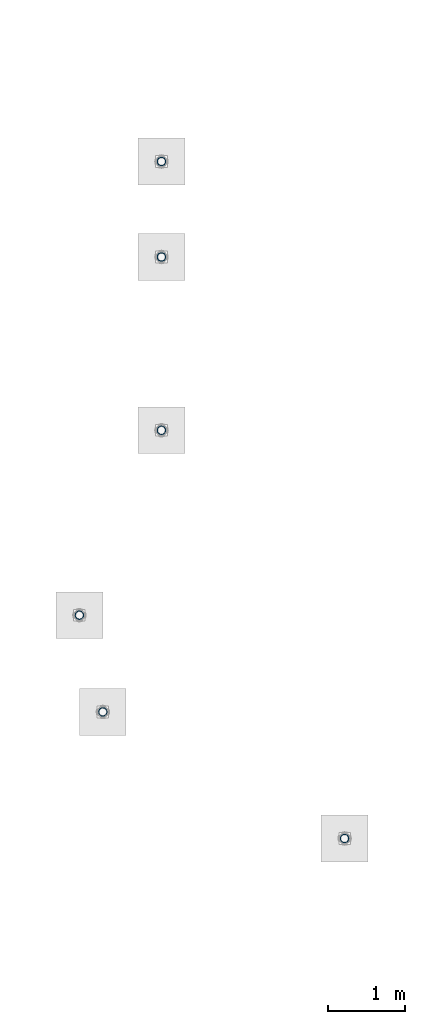
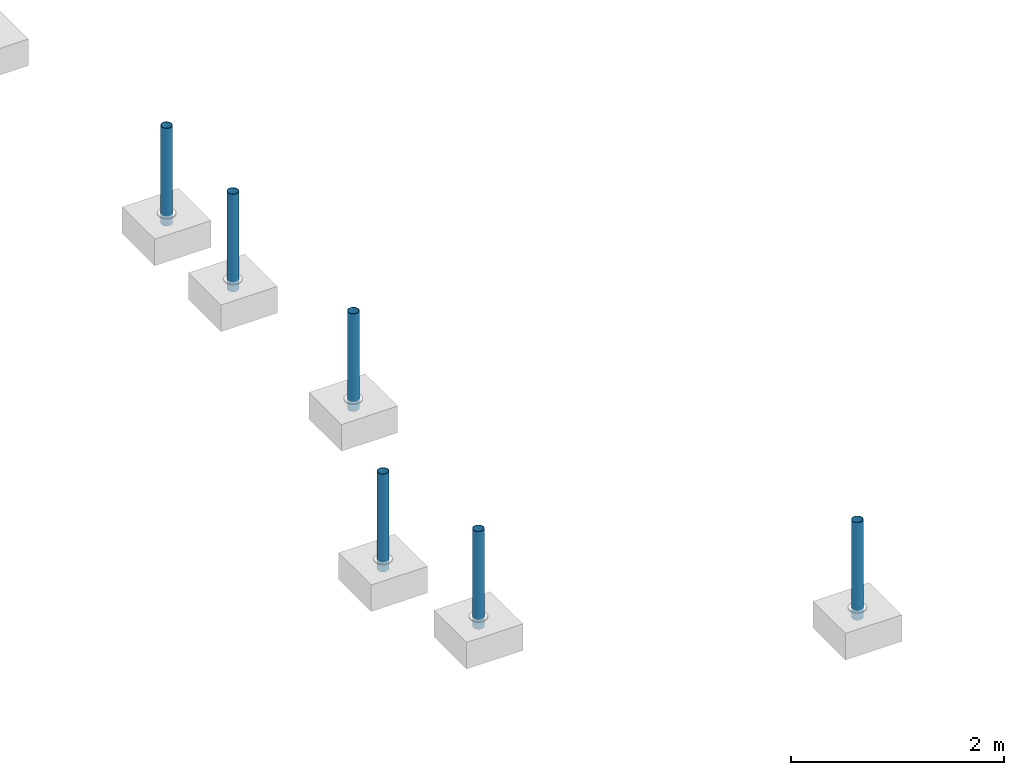
# One storey, part 1341 of 3843: 6 columns, 6 elements without a shape of their own.
"""IFC2X3 building model written with IfcOpenShell, lengths in millimetres."""

from ifc_helpers import new_model, si_unit, frame, origin_with_axes, place, context, subcontext, project, spatial, faceted_brep, material, type_object, element, aggregate, save


model = new_model("IFC2X3")

# Units and contexts
model_context = context("Model", 3, precision=1e-05, world=origin_with_axes())
body_context = subcontext(model_context, "Body", "Model", "MODEL_VIEW")
ifc_project = project(units=[si_unit("LENGTHUNIT", "METRE", prefix="MILLI"), si_unit("AREAUNIT", "SQUARE_METRE"), si_unit("VOLUMEUNIT", "CUBIC_METRE"), si_unit("MASSUNIT", "GRAM", prefix="KILO"), si_unit("TIMEUNIT", "SECOND"), si_unit("PLANEANGLEUNIT", "RADIAN"), si_unit("SOLIDANGLEUNIT", "STERADIAN"), si_unit("THERMODYNAMICTEMPERATUREUNIT", "DEGREE_CELSIUS"), si_unit("LUMINOUSINTENSITYUNIT", "LUMEN")], contexts=[model_context])

# Site, building, storey
site_placement = place(None, origin_with_axes())
site = spatial("IfcSite", under=ifc_project, at=site_placement, CompositionType="ELEMENT")
building_placement = place(site_placement, origin_with_axes())
building = spatial("IfcBuilding", under=site, at=building_placement, Name="Undefined", CompositionType="ELEMENT")
storey_placement = place(building_placement, origin_with_axes())
storey = spatial("IfcBuildingStorey", under=building, at=storey_placement, Name="Undefined", CompositionType="ELEMENT", Elevation=0.0)

# Assembly, column
assembly_1_placement = place(storey_placement, origin_with_axes())
assembly_1 = element("IfcElementAssembly", 1, at=assembly_1_placement, inside=storey, Name="PIPE_BOLLARD", AssemblyPlace="NOTDEFINED", PredefinedType="RIGID_FRAME")
ifc_material = material()
column_type = type_object("IfcColumnType", Name="PIPE4SCH40", PredefinedType="NOTDEFINED")
column_1_placement = place(assembly_1_placement, frame((-13009.9315797985, 80350.2009584904, 30378.4), z_axis=(-1.0, 0.0, 0.0), x_axis=(0.0, 0.0, 1.0)))
column_1 = element("IfcColumn", 2, at=column_1_placement, type_object=column_type, material=ifc_material, Name="PIPE_BOLLARD", ObjectType="PIPE4SCH40", context=body_context, shape_type="Brep", body=[
    faceted_brep([(0.0, -51.1301999999996, 0.0), (0.0, -48.6277098894743, 15.8001007257844), (1117.6, -48.6277098894743, 15.8001007257844), (1117.6, -51.1301999999996, 0.0), (0.0, -41.3652007257897, 30.0535775067692), (1117.6, -41.3652007257897, 30.0535775067692), (0.0, -30.0535775067647, 41.3652007257915), (1117.6, -30.0535775067647, 41.3652007257915), (0.0, -15.8001007257899, 48.6277098894789), (1117.6, -15.8001007257899, 48.6277098894789), (0.0, 0.0, 51.1301999999996), (1117.6, 0.0, 51.1301999999996), (0.0, 15.8001007257899, 48.6277098894789), (1117.6, 15.8001007257899, 48.6277098894789), (0.0, 30.0535775067647, 41.3652007257915), (1117.6, 30.0535775067647, 41.3652007257915), (0.0, 41.3652007257897, 30.0535775067692), (1117.6, 41.3652007257897, 30.0535775067692), (0.0, 48.6277098894743, 15.8001007257844), (1117.6, 48.6277098894743, 15.8001007257844), (0.0, 51.1301999999996, 0.0), (1117.6, 51.1301999999996, 0.0), (0.0, 48.6277098894743, -15.8001007257844), (1117.6, 48.6277098894743, -15.8001007257844), (0.0, 41.3652007257897, -30.0535775067692), (1117.6, 41.3652007257897, -30.0535775067692), (0.0, 30.0535775067647, -41.3652007257915), (1117.6, 30.0535775067647, -41.3652007257915), (0.0, 15.8001007257899, -48.6277098894789), (1117.6, 15.8001007257899, -48.6277098894789), (0.0, 0.0, -51.1301999999996), (1117.6, 0.0, -51.1301999999996), (0.0, -15.8001007257899, -48.6277098894789), (1117.6, -15.8001007257899, -48.6277098894789), (0.0, -30.0535775067647, -41.3652007257915), (1117.6, -30.0535775067647, -41.3652007257915), (0.0, -41.3652007257897, -30.0535775067692), (1117.6, -41.3652007257897, -30.0535775067692), (0.0, -48.6277098894743, -15.8001007257844), (1117.6, -48.6277098894743, -15.8001007257844), (0.0, -57.1499999999996, 0.0), (0.0, -54.3528799062678, -17.6603212285263), (1117.6, -54.3528799062678, -17.6603212285263), (1117.6, -57.1499999999996, 0.0), (0.0, -46.2353212285279, -33.5919271685125), (1117.6, -46.2353212285279, -33.5919271685125), (0.0, -33.5919271685152, -46.2353212285234), (1117.6, -33.5919271685152, -46.2353212285234), (0.0, -17.6603212285281, -54.3528799062624), (1117.6, -17.6603212285281, -54.3528799062624), (0.0, 0.0, -57.1499999999942), (1117.6, 0.0, -57.1499999999942), (0.0, 17.6603212285281, -54.3528799062624), (1117.6, 17.6603212285281, -54.3528799062624), (0.0, 33.5919271685152, -46.2353212285234), (1117.6, 33.5919271685152, -46.2353212285234), (0.0, 46.2353212285279, -33.5919271685125), (1117.6, 46.2353212285279, -33.5919271685125), (0.0, 54.3528799062678, -17.6603212285263), (1117.6, 54.3528799062678, -17.6603212285263), (0.0, 57.1499999999996, 0.0), (1117.6, 57.1499999999996, 0.0), (0.0, 54.3528799062678, 17.6603212285263), (1117.6, 54.3528799062678, 17.6603212285263), (0.0, 46.2353212285279, 33.5919271685125), (1117.6, 46.2353212285279, 33.5919271685125), (0.0, 33.5919271685152, 46.2353212285234), (1117.6, 33.5919271685152, 46.2353212285234), (0.0, 17.6603212285281, 54.3528799062624), (1117.6, 17.6603212285281, 54.3528799062624), (0.0, 0.0, 57.1499999999942), (1117.6, 0.0, 57.1499999999942), (0.0, -17.6603212285281, 54.3528799062624), (1117.6, -17.6603212285281, 54.3528799062624), (0.0, -33.5919271685152, 46.2353212285234), (1117.6, -33.5919271685152, 46.2353212285234), (0.0, -46.2353212285279, 33.5919271685125), (1117.6, -46.2353212285279, 33.5919271685125), (0.0, -54.3528799062678, 17.6603212285263), (1117.6, -54.3528799062678, 17.6603212285263)], [[[0, 1, 2, 3]], [[1, 4, 5, 2]], [[4, 6, 7, 5]], [[6, 8, 9, 7]], [[8, 10, 11, 9]], [[10, 12, 13, 11]], [[12, 14, 15, 13]], [[14, 16, 17, 15]], [[16, 18, 19, 17]], [[18, 20, 21, 19]], [[20, 22, 23, 21]], [[22, 24, 25, 23]], [[24, 26, 27, 25]], [[26, 28, 29, 27]], [[28, 30, 31, 29]], [[30, 32, 33, 31]], [[32, 34, 35, 33]], [[34, 36, 37, 35]], [[36, 38, 39, 37]], [[38, 0, 3, 39]], [[40, 41, 42, 43]], [[41, 44, 45, 42]], [[44, 46, 47, 45]], [[46, 48, 49, 47]], [[48, 50, 51, 49]], [[50, 52, 53, 51]], [[52, 54, 55, 53]], [[54, 56, 57, 55]], [[56, 58, 59, 57]], [[58, 60, 61, 59]], [[60, 62, 63, 61]], [[62, 64, 65, 63]], [[64, 66, 67, 65]], [[66, 68, 69, 67]], [[68, 70, 71, 69]], [[70, 72, 73, 71]], [[72, 74, 75, 73]], [[74, 76, 77, 75]], [[76, 78, 79, 77]], [[78, 40, 43, 79]], [[45, 47, 49, 51, 53, 55, 57, 59, 61, 63, 65, 67, 69, 71, 73, 75, 77, 79, 43, 42], [5, 7, 9, 11, 13, 15, 17, 19, 21, 23, 25, 27, 29, 31, 33, 35, 37, 39, 3, 2]], [[78, 76, 74, 72, 70, 68, 66, 64, 62, 60, 58, 56, 54, 52, 50, 48, 46, 44, 41, 40], [38, 36, 34, 32, 30, 28, 26, 24, 22, 20, 18, 16, 14, 12, 10, 8, 6, 4, 1, 0]]]),
])
aggregate(assembly_1, [column_1])

assembly_2_placement = place(storey_placement, origin_with_axes())
assembly_2 = element("IfcElementAssembly", 3, at=assembly_2_placement, inside=storey, Name="PIPE_BOLLARD", AssemblyPlace="NOTDEFINED", PredefinedType="RIGID_FRAME")
column_2_placement = place(assembly_2_placement, frame((-16161.9587099254, 81999.8381807804, 30378.4), z_axis=(-1.0, 0.0, 0.0), x_axis=(0.0, 0.0, 1.0)))
column_2 = element("IfcColumn", 4, at=column_2_placement, type_object=column_type, material=ifc_material, Name="PIPE_BOLLARD", ObjectType="PIPE4SCH40", context=body_context, shape_type="Brep", body=[
    faceted_brep([(0.0, -51.1301999999996, 0.0), (0.0, -48.6277098894743, 15.8001007257844), (1117.6, -48.6277098894743, 15.8001007257844), (1117.6, -51.1301999999996, 0.0), (0.0, -41.3652007257897, 30.0535775067692), (1117.6, -41.3652007257897, 30.0535775067692), (0.0, -30.0535775067647, 41.3652007257915), (1117.6, -30.0535775067647, 41.3652007257915), (0.0, -15.8001007257899, 48.6277098894789), (1117.6, -15.8001007257899, 48.6277098894789), (0.0, 0.0, 51.1301999999996), (1117.6, 0.0, 51.1301999999996), (0.0, 15.8001007257899, 48.6277098894789), (1117.6, 15.8001007257899, 48.6277098894789), (0.0, 30.0535775067647, 41.3652007257915), (1117.6, 30.0535775067647, 41.3652007257915), (0.0, 41.3652007257897, 30.0535775067692), (1117.6, 41.3652007257897, 30.0535775067692), (0.0, 48.6277098894743, 15.8001007257844), (1117.6, 48.6277098894743, 15.8001007257844), (0.0, 51.1301999999996, 0.0), (1117.6, 51.1301999999996, 0.0), (0.0, 48.6277098894743, -15.8001007257844), (1117.6, 48.6277098894743, -15.8001007257844), (0.0, 41.3652007257897, -30.0535775067692), (1117.6, 41.3652007257897, -30.0535775067692), (0.0, 30.0535775067647, -41.3652007257915), (1117.6, 30.0535775067647, -41.3652007257915), (0.0, 15.8001007257899, -48.6277098894789), (1117.6, 15.8001007257899, -48.6277098894789), (0.0, 0.0, -51.1301999999996), (1117.6, 0.0, -51.1301999999996), (0.0, -15.8001007257899, -48.6277098894789), (1117.6, -15.8001007257899, -48.6277098894789), (0.0, -30.0535775067647, -41.3652007257915), (1117.6, -30.0535775067647, -41.3652007257915), (0.0, -41.3652007257897, -30.0535775067692), (1117.6, -41.3652007257897, -30.0535775067692), (0.0, -48.6277098894743, -15.8001007257844), (1117.6, -48.6277098894743, -15.8001007257844), (0.0, -57.1499999999996, 0.0), (0.0, -54.3528799062678, -17.6603212285263), (1117.6, -54.3528799062678, -17.6603212285263), (1117.6, -57.1499999999996, 0.0), (0.0, -46.2353212285279, -33.5919271685125), (1117.6, -46.2353212285279, -33.5919271685125), (0.0, -33.5919271685152, -46.2353212285234), (1117.6, -33.5919271685152, -46.2353212285234), (0.0, -17.6603212285281, -54.3528799062624), (1117.6, -17.6603212285281, -54.3528799062624), (0.0, 0.0, -57.1499999999942), (1117.6, 0.0, -57.1499999999942), (0.0, 17.6603212285281, -54.3528799062624), (1117.6, 17.6603212285281, -54.3528799062624), (0.0, 33.5919271685152, -46.2353212285234), (1117.6, 33.5919271685152, -46.2353212285234), (0.0, 46.2353212285279, -33.5919271685125), (1117.6, 46.2353212285279, -33.5919271685125), (0.0, 54.3528799062678, -17.6603212285263), (1117.6, 54.3528799062678, -17.6603212285263), (0.0, 57.1499999999996, 0.0), (1117.6, 57.1499999999996, 0.0), (0.0, 54.3528799062678, 17.6603212285263), (1117.6, 54.3528799062678, 17.6603212285263), (0.0, 46.2353212285279, 33.5919271685125), (1117.6, 46.2353212285279, 33.5919271685125), (0.0, 33.5919271685152, 46.2353212285234), (1117.6, 33.5919271685152, 46.2353212285234), (0.0, 17.6603212285281, 54.3528799062624), (1117.6, 17.6603212285281, 54.3528799062624), (0.0, 0.0, 57.1499999999942), (1117.6, 0.0, 57.1499999999942), (0.0, -17.6603212285281, 54.3528799062624), (1117.6, -17.6603212285281, 54.3528799062624), (0.0, -33.5919271685152, 46.2353212285234), (1117.6, -33.5919271685152, 46.2353212285234), (0.0, -46.2353212285279, 33.5919271685125), (1117.6, -46.2353212285279, 33.5919271685125), (0.0, -54.3528799062678, 17.6603212285263), (1117.6, -54.3528799062678, 17.6603212285263)], [[[0, 1, 2, 3]], [[1, 4, 5, 2]], [[4, 6, 7, 5]], [[6, 8, 9, 7]], [[8, 10, 11, 9]], [[10, 12, 13, 11]], [[12, 14, 15, 13]], [[14, 16, 17, 15]], [[16, 18, 19, 17]], [[18, 20, 21, 19]], [[20, 22, 23, 21]], [[22, 24, 25, 23]], [[24, 26, 27, 25]], [[26, 28, 29, 27]], [[28, 30, 31, 29]], [[30, 32, 33, 31]], [[32, 34, 35, 33]], [[34, 36, 37, 35]], [[36, 38, 39, 37]], [[38, 0, 3, 39]], [[40, 41, 42, 43]], [[41, 44, 45, 42]], [[44, 46, 47, 45]], [[46, 48, 49, 47]], [[48, 50, 51, 49]], [[50, 52, 53, 51]], [[52, 54, 55, 53]], [[54, 56, 57, 55]], [[56, 58, 59, 57]], [[58, 60, 61, 59]], [[60, 62, 63, 61]], [[62, 64, 65, 63]], [[64, 66, 67, 65]], [[66, 68, 69, 67]], [[68, 70, 71, 69]], [[70, 72, 73, 71]], [[72, 74, 75, 73]], [[74, 76, 77, 75]], [[76, 78, 79, 77]], [[78, 40, 43, 79]], [[45, 47, 49, 51, 53, 55, 57, 59, 61, 63, 65, 67, 69, 71, 73, 75, 77, 79, 43, 42], [5, 7, 9, 11, 13, 15, 17, 19, 21, 23, 25, 27, 29, 31, 33, 35, 37, 39, 3, 2]], [[78, 76, 74, 72, 70, 68, 66, 64, 62, 60, 58, 56, 54, 52, 50, 48, 46, 44, 41, 40], [38, 36, 34, 32, 30, 28, 26, 24, 22, 20, 18, 16, 14, 12, 10, 8, 6, 4, 1, 0]]]),
])
aggregate(assembly_2, [column_2])

assembly_3_placement = place(storey_placement, origin_with_axes())
assembly_3 = element("IfcElementAssembly", 5, at=assembly_3_placement, inside=storey, Name="PIPE_BOLLARD", AssemblyPlace="NOTDEFINED", PredefinedType="RIGID_FRAME")
column_3_placement = place(assembly_3_placement, frame((-16467.6075136364, 83260.6490328312, 30378.4), z_axis=(-1.0, 0.0, 0.0), x_axis=(0.0, 0.0, 1.0)))
column_3 = element("IfcColumn", 6, at=column_3_placement, type_object=column_type, material=ifc_material, Name="PIPE_BOLLARD", ObjectType="PIPE4SCH40", context=body_context, shape_type="Brep", body=[
    faceted_brep([(0.0, -51.1301999999996, 0.0), (0.0, -48.6277098894743, 15.8001007257844), (1117.6, -48.6277098894743, 15.8001007257844), (1117.6, -51.1301999999996, 0.0), (0.0, -41.3652007257897, 30.0535775067692), (1117.6, -41.3652007257897, 30.0535775067692), (0.0, -30.0535775067647, 41.3652007257915), (1117.6, -30.0535775067647, 41.3652007257915), (0.0, -15.8001007257899, 48.6277098894789), (1117.6, -15.8001007257899, 48.6277098894789), (0.0, 0.0, 51.1301999999996), (1117.6, 0.0, 51.1301999999996), (0.0, 15.8001007257899, 48.6277098894789), (1117.6, 15.8001007257899, 48.6277098894789), (0.0, 30.0535775067647, 41.3652007257915), (1117.6, 30.0535775067647, 41.3652007257915), (0.0, 41.3652007257897, 30.0535775067692), (1117.6, 41.3652007257897, 30.0535775067692), (0.0, 48.6277098894743, 15.8001007257844), (1117.6, 48.6277098894743, 15.8001007257844), (0.0, 51.1301999999996, 0.0), (1117.6, 51.1301999999996, 0.0), (0.0, 48.6277098894743, -15.8001007257844), (1117.6, 48.6277098894743, -15.8001007257844), (0.0, 41.3652007257897, -30.0535775067692), (1117.6, 41.3652007257897, -30.0535775067692), (0.0, 30.0535775067647, -41.3652007257915), (1117.6, 30.0535775067647, -41.3652007257915), (0.0, 15.8001007257899, -48.6277098894789), (1117.6, 15.8001007257899, -48.6277098894789), (0.0, 0.0, -51.1301999999996), (1117.6, 0.0, -51.1301999999996), (0.0, -15.8001007257899, -48.6277098894789), (1117.6, -15.8001007257899, -48.6277098894789), (0.0, -30.0535775067647, -41.3652007257915), (1117.6, -30.0535775067647, -41.3652007257915), (0.0, -41.3652007257897, -30.0535775067692), (1117.6, -41.3652007257897, -30.0535775067692), (0.0, -48.6277098894743, -15.8001007257844), (1117.6, -48.6277098894743, -15.8001007257844), (0.0, -57.1499999999996, 0.0), (0.0, -54.3528799062678, -17.6603212285263), (1117.6, -54.3528799062678, -17.6603212285263), (1117.6, -57.1499999999996, 0.0), (0.0, -46.2353212285279, -33.5919271685125), (1117.6, -46.2353212285279, -33.5919271685125), (0.0, -33.5919271685152, -46.2353212285234), (1117.6, -33.5919271685152, -46.2353212285234), (0.0, -17.6603212285281, -54.3528799062624), (1117.6, -17.6603212285281, -54.3528799062624), (0.0, 0.0, -57.1499999999942), (1117.6, 0.0, -57.1499999999942), (0.0, 17.6603212285281, -54.3528799062624), (1117.6, 17.6603212285281, -54.3528799062624), (0.0, 33.5919271685152, -46.2353212285234), (1117.6, 33.5919271685152, -46.2353212285234), (0.0, 46.2353212285279, -33.5919271685125), (1117.6, 46.2353212285279, -33.5919271685125), (0.0, 54.3528799062678, -17.6603212285263), (1117.6, 54.3528799062678, -17.6603212285263), (0.0, 57.1499999999996, 0.0), (1117.6, 57.1499999999996, 0.0), (0.0, 54.3528799062678, 17.6603212285263), (1117.6, 54.3528799062678, 17.6603212285263), (0.0, 46.2353212285279, 33.5919271685125), (1117.6, 46.2353212285279, 33.5919271685125), (0.0, 33.5919271685152, 46.2353212285234), (1117.6, 33.5919271685152, 46.2353212285234), (0.0, 17.6603212285281, 54.3528799062624), (1117.6, 17.6603212285281, 54.3528799062624), (0.0, 0.0, 57.1499999999942), (1117.6, 0.0, 57.1499999999942), (0.0, -17.6603212285281, 54.3528799062624), (1117.6, -17.6603212285281, 54.3528799062624), (0.0, -33.5919271685152, 46.2353212285234), (1117.6, -33.5919271685152, 46.2353212285234), (0.0, -46.2353212285279, 33.5919271685125), (1117.6, -46.2353212285279, 33.5919271685125), (0.0, -54.3528799062678, 17.6603212285263), (1117.6, -54.3528799062678, 17.6603212285263)], [[[0, 1, 2, 3]], [[1, 4, 5, 2]], [[4, 6, 7, 5]], [[6, 8, 9, 7]], [[8, 10, 11, 9]], [[10, 12, 13, 11]], [[12, 14, 15, 13]], [[14, 16, 17, 15]], [[16, 18, 19, 17]], [[18, 20, 21, 19]], [[20, 22, 23, 21]], [[22, 24, 25, 23]], [[24, 26, 27, 25]], [[26, 28, 29, 27]], [[28, 30, 31, 29]], [[30, 32, 33, 31]], [[32, 34, 35, 33]], [[34, 36, 37, 35]], [[36, 38, 39, 37]], [[38, 0, 3, 39]], [[40, 41, 42, 43]], [[41, 44, 45, 42]], [[44, 46, 47, 45]], [[46, 48, 49, 47]], [[48, 50, 51, 49]], [[50, 52, 53, 51]], [[52, 54, 55, 53]], [[54, 56, 57, 55]], [[56, 58, 59, 57]], [[58, 60, 61, 59]], [[60, 62, 63, 61]], [[62, 64, 65, 63]], [[64, 66, 67, 65]], [[66, 68, 69, 67]], [[68, 70, 71, 69]], [[70, 72, 73, 71]], [[72, 74, 75, 73]], [[74, 76, 77, 75]], [[76, 78, 79, 77]], [[78, 40, 43, 79]], [[45, 47, 49, 51, 53, 55, 57, 59, 61, 63, 65, 67, 69, 71, 73, 75, 77, 79, 43, 42], [5, 7, 9, 11, 13, 15, 17, 19, 21, 23, 25, 27, 29, 31, 33, 35, 37, 39, 3, 2]], [[78, 76, 74, 72, 70, 68, 66, 64, 62, 60, 58, 56, 54, 52, 50, 48, 46, 44, 41, 40], [38, 36, 34, 32, 30, 28, 26, 24, 22, 20, 18, 16, 14, 12, 10, 8, 6, 4, 1, 0]]]),
])
aggregate(assembly_3, [column_3])

assembly_4_placement = place(storey_placement, origin_with_axes())
assembly_4 = element("IfcElementAssembly", 7, at=assembly_4_placement, inside=storey, Name="PIPE_BOLLARD", AssemblyPlace="NOTDEFINED", PredefinedType="RIGID_FRAME")
column_4_placement = place(assembly_4_placement, frame((-15397.757813, 89174.439064, 30378.4), z_axis=(-1.0, 0.0, 0.0), x_axis=(0.0, 0.0, 1.0)))
column_4 = element("IfcColumn", 8, at=column_4_placement, type_object=column_type, material=ifc_material, Name="PIPE_BOLLARD", ObjectType="PIPE4SCH40", context=body_context, shape_type="Brep", body=[
    faceted_brep([(0.0, -51.1301999999996, 0.0), (0.0, -48.6277098894743, 15.8001007257844), (1117.6, -48.6277098894743, 15.8001007257844), (1117.6, -51.1301999999996, 0.0), (0.0, -41.3652007257897, 30.0535775067692), (1117.6, -41.3652007257897, 30.0535775067692), (0.0, -30.0535775067647, 41.3652007257915), (1117.6, -30.0535775067647, 41.3652007257915), (0.0, -15.8001007257899, 48.6277098894789), (1117.6, -15.8001007257899, 48.6277098894789), (0.0, 0.0, 51.1301999999996), (1117.6, 0.0, 51.1301999999996), (0.0, 15.8001007257899, 48.6277098894789), (1117.6, 15.8001007257899, 48.6277098894789), (0.0, 30.0535775067647, 41.3652007257915), (1117.6, 30.0535775067647, 41.3652007257915), (0.0, 41.3652007257897, 30.0535775067692), (1117.6, 41.3652007257897, 30.0535775067692), (0.0, 48.6277098894743, 15.8001007257844), (1117.6, 48.6277098894743, 15.8001007257844), (0.0, 51.1301999999996, 0.0), (1117.6, 51.1301999999996, 0.0), (0.0, 48.6277098894743, -15.8001007257844), (1117.6, 48.6277098894743, -15.8001007257844), (0.0, 41.3652007257897, -30.0535775067692), (1117.6, 41.3652007257897, -30.0535775067692), (0.0, 30.0535775067647, -41.3652007257915), (1117.6, 30.0535775067647, -41.3652007257915), (0.0, 15.8001007257899, -48.6277098894789), (1117.6, 15.8001007257899, -48.6277098894789), (0.0, 0.0, -51.1301999999996), (1117.6, 0.0, -51.1301999999996), (0.0, -15.8001007257899, -48.6277098894789), (1117.6, -15.8001007257899, -48.6277098894789), (0.0, -30.0535775067647, -41.3652007257915), (1117.6, -30.0535775067647, -41.3652007257915), (0.0, -41.3652007257897, -30.0535775067692), (1117.6, -41.3652007257897, -30.0535775067692), (0.0, -48.6277098894743, -15.8001007257844), (1117.6, -48.6277098894743, -15.8001007257844), (0.0, -57.1499999999996, 0.0), (0.0, -54.3528799062678, -17.6603212285263), (1117.6, -54.3528799062678, -17.6603212285263), (1117.6, -57.1499999999996, 0.0), (0.0, -46.2353212285279, -33.5919271685125), (1117.6, -46.2353212285279, -33.5919271685125), (0.0, -33.5919271685152, -46.2353212285234), (1117.6, -33.5919271685152, -46.2353212285234), (0.0, -17.6603212285281, -54.3528799062624), (1117.6, -17.6603212285281, -54.3528799062624), (0.0, 0.0, -57.1499999999942), (1117.6, 0.0, -57.1499999999942), (0.0, 17.6603212285281, -54.3528799062624), (1117.6, 17.6603212285281, -54.3528799062624), (0.0, 33.5919271685152, -46.2353212285234), (1117.6, 33.5919271685152, -46.2353212285234), (0.0, 46.2353212285279, -33.5919271685125), (1117.6, 46.2353212285279, -33.5919271685125), (0.0, 54.3528799062678, -17.6603212285263), (1117.6, 54.3528799062678, -17.6603212285263), (0.0, 57.1499999999996, 0.0), (1117.6, 57.1499999999996, 0.0), (0.0, 54.3528799062678, 17.6603212285263), (1117.6, 54.3528799062678, 17.6603212285263), (0.0, 46.2353212285279, 33.5919271685125), (1117.6, 46.2353212285279, 33.5919271685125), (0.0, 33.5919271685152, 46.2353212285234), (1117.6, 33.5919271685152, 46.2353212285234), (0.0, 17.6603212285281, 54.3528799062624), (1117.6, 17.6603212285281, 54.3528799062624), (0.0, 0.0, 57.1499999999942), (1117.6, 0.0, 57.1499999999942), (0.0, -17.6603212285281, 54.3528799062624), (1117.6, -17.6603212285281, 54.3528799062624), (0.0, -33.5919271685152, 46.2353212285234), (1117.6, -33.5919271685152, 46.2353212285234), (0.0, -46.2353212285279, 33.5919271685125), (1117.6, -46.2353212285279, 33.5919271685125), (0.0, -54.3528799062678, 17.6603212285263), (1117.6, -54.3528799062678, 17.6603212285263)], [[[0, 1, 2, 3]], [[1, 4, 5, 2]], [[4, 6, 7, 5]], [[6, 8, 9, 7]], [[8, 10, 11, 9]], [[10, 12, 13, 11]], [[12, 14, 15, 13]], [[14, 16, 17, 15]], [[16, 18, 19, 17]], [[18, 20, 21, 19]], [[20, 22, 23, 21]], [[22, 24, 25, 23]], [[24, 26, 27, 25]], [[26, 28, 29, 27]], [[28, 30, 31, 29]], [[30, 32, 33, 31]], [[32, 34, 35, 33]], [[34, 36, 37, 35]], [[36, 38, 39, 37]], [[38, 0, 3, 39]], [[40, 41, 42, 43]], [[41, 44, 45, 42]], [[44, 46, 47, 45]], [[46, 48, 49, 47]], [[48, 50, 51, 49]], [[50, 52, 53, 51]], [[52, 54, 55, 53]], [[54, 56, 57, 55]], [[56, 58, 59, 57]], [[58, 60, 61, 59]], [[60, 62, 63, 61]], [[62, 64, 65, 63]], [[64, 66, 67, 65]], [[66, 68, 69, 67]], [[68, 70, 71, 69]], [[70, 72, 73, 71]], [[72, 74, 75, 73]], [[74, 76, 77, 75]], [[76, 78, 79, 77]], [[78, 40, 43, 79]], [[45, 47, 49, 51, 53, 55, 57, 59, 61, 63, 65, 67, 69, 71, 73, 75, 77, 79, 43, 42], [5, 7, 9, 11, 13, 15, 17, 19, 21, 23, 25, 27, 29, 31, 33, 35, 37, 39, 3, 2]], [[78, 76, 74, 72, 70, 68, 66, 64, 62, 60, 58, 56, 54, 52, 50, 48, 46, 44, 41, 40], [38, 36, 34, 32, 30, 28, 26, 24, 22, 20, 18, 16, 14, 12, 10, 8, 6, 4, 1, 0]]]),
])
aggregate(assembly_4, [column_4])

assembly_5_placement = place(storey_placement, origin_with_axes())
assembly_5 = element("IfcElementAssembly", 9, at=assembly_5_placement, inside=storey, Name="PIPE_BOLLARD", AssemblyPlace="NOTDEFINED", PredefinedType="RIGID_FRAME")
column_5_placement = place(assembly_5_placement, frame((-15397.757813, 87930.235939, 30378.4), z_axis=(-1.0, 0.0, 0.0), x_axis=(0.0, 0.0, 1.0)))
column_5 = element("IfcColumn", 10, at=column_5_placement, type_object=column_type, material=ifc_material, Name="PIPE_BOLLARD", ObjectType="PIPE4SCH40", context=body_context, shape_type="Brep", body=[
    faceted_brep([(0.0, -51.1301999999996, 0.0), (0.0, -48.6277098894743, 15.8001007257844), (1117.6, -48.6277098894743, 15.8001007257844), (1117.6, -51.1301999999996, 0.0), (0.0, -41.3652007257897, 30.0535775067692), (1117.6, -41.3652007257897, 30.0535775067692), (0.0, -30.0535775067647, 41.3652007257915), (1117.6, -30.0535775067647, 41.3652007257915), (0.0, -15.8001007257899, 48.6277098894789), (1117.6, -15.8001007257899, 48.6277098894789), (0.0, 0.0, 51.1301999999996), (1117.6, 0.0, 51.1301999999996), (0.0, 15.8001007257899, 48.6277098894789), (1117.6, 15.8001007257899, 48.6277098894789), (0.0, 30.0535775067647, 41.3652007257915), (1117.6, 30.0535775067647, 41.3652007257915), (0.0, 41.3652007257897, 30.0535775067692), (1117.6, 41.3652007257897, 30.0535775067692), (0.0, 48.6277098894743, 15.8001007257844), (1117.6, 48.6277098894743, 15.8001007257844), (0.0, 51.1301999999996, 0.0), (1117.6, 51.1301999999996, 0.0), (0.0, 48.6277098894743, -15.8001007257844), (1117.6, 48.6277098894743, -15.8001007257844), (0.0, 41.3652007257897, -30.0535775067692), (1117.6, 41.3652007257897, -30.0535775067692), (0.0, 30.0535775067647, -41.3652007257915), (1117.6, 30.0535775067647, -41.3652007257915), (0.0, 15.8001007257899, -48.6277098894789), (1117.6, 15.8001007257899, -48.6277098894789), (0.0, 0.0, -51.1301999999996), (1117.6, 0.0, -51.1301999999996), (0.0, -15.8001007257899, -48.6277098894789), (1117.6, -15.8001007257899, -48.6277098894789), (0.0, -30.0535775067647, -41.3652007257915), (1117.6, -30.0535775067647, -41.3652007257915), (0.0, -41.3652007257897, -30.0535775067692), (1117.6, -41.3652007257897, -30.0535775067692), (0.0, -48.6277098894743, -15.8001007257844), (1117.6, -48.6277098894743, -15.8001007257844), (0.0, -57.1499999999996, 0.0), (0.0, -54.3528799062678, -17.6603212285263), (1117.6, -54.3528799062678, -17.6603212285263), (1117.6, -57.1499999999996, 0.0), (0.0, -46.2353212285279, -33.5919271685125), (1117.6, -46.2353212285279, -33.5919271685125), (0.0, -33.5919271685152, -46.2353212285234), (1117.6, -33.5919271685152, -46.2353212285234), (0.0, -17.6603212285281, -54.3528799062624), (1117.6, -17.6603212285281, -54.3528799062624), (0.0, 0.0, -57.1499999999942), (1117.6, 0.0, -57.1499999999942), (0.0, 17.6603212285281, -54.3528799062624), (1117.6, 17.6603212285281, -54.3528799062624), (0.0, 33.5919271685152, -46.2353212285234), (1117.6, 33.5919271685152, -46.2353212285234), (0.0, 46.2353212285279, -33.5919271685125), (1117.6, 46.2353212285279, -33.5919271685125), (0.0, 54.3528799062678, -17.6603212285263), (1117.6, 54.3528799062678, -17.6603212285263), (0.0, 57.1499999999996, 0.0), (1117.6, 57.1499999999996, 0.0), (0.0, 54.3528799062678, 17.6603212285263), (1117.6, 54.3528799062678, 17.6603212285263), (0.0, 46.2353212285279, 33.5919271685125), (1117.6, 46.2353212285279, 33.5919271685125), (0.0, 33.5919271685152, 46.2353212285234), (1117.6, 33.5919271685152, 46.2353212285234), (0.0, 17.6603212285281, 54.3528799062624), (1117.6, 17.6603212285281, 54.3528799062624), (0.0, 0.0, 57.1499999999942), (1117.6, 0.0, 57.1499999999942), (0.0, -17.6603212285281, 54.3528799062624), (1117.6, -17.6603212285281, 54.3528799062624), (0.0, -33.5919271685152, 46.2353212285234), (1117.6, -33.5919271685152, 46.2353212285234), (0.0, -46.2353212285279, 33.5919271685125), (1117.6, -46.2353212285279, 33.5919271685125), (0.0, -54.3528799062678, 17.6603212285263), (1117.6, -54.3528799062678, 17.6603212285263)], [[[0, 1, 2, 3]], [[1, 4, 5, 2]], [[4, 6, 7, 5]], [[6, 8, 9, 7]], [[8, 10, 11, 9]], [[10, 12, 13, 11]], [[12, 14, 15, 13]], [[14, 16, 17, 15]], [[16, 18, 19, 17]], [[18, 20, 21, 19]], [[20, 22, 23, 21]], [[22, 24, 25, 23]], [[24, 26, 27, 25]], [[26, 28, 29, 27]], [[28, 30, 31, 29]], [[30, 32, 33, 31]], [[32, 34, 35, 33]], [[34, 36, 37, 35]], [[36, 38, 39, 37]], [[38, 0, 3, 39]], [[40, 41, 42, 43]], [[41, 44, 45, 42]], [[44, 46, 47, 45]], [[46, 48, 49, 47]], [[48, 50, 51, 49]], [[50, 52, 53, 51]], [[52, 54, 55, 53]], [[54, 56, 57, 55]], [[56, 58, 59, 57]], [[58, 60, 61, 59]], [[60, 62, 63, 61]], [[62, 64, 65, 63]], [[64, 66, 67, 65]], [[66, 68, 69, 67]], [[68, 70, 71, 69]], [[70, 72, 73, 71]], [[72, 74, 75, 73]], [[74, 76, 77, 75]], [[76, 78, 79, 77]], [[78, 40, 43, 79]], [[45, 47, 49, 51, 53, 55, 57, 59, 61, 63, 65, 67, 69, 71, 73, 75, 77, 79, 43, 42], [5, 7, 9, 11, 13, 15, 17, 19, 21, 23, 25, 27, 29, 31, 33, 35, 37, 39, 3, 2]], [[78, 76, 74, 72, 70, 68, 66, 64, 62, 60, 58, 56, 54, 52, 50, 48, 46, 44, 41, 40], [38, 36, 34, 32, 30, 28, 26, 24, 22, 20, 18, 16, 14, 12, 10, 8, 6, 4, 1, 0]]]),
])
aggregate(assembly_5, [column_5])

assembly_6_placement = place(storey_placement, origin_with_axes())
assembly_6 = element("IfcElementAssembly", 11, at=assembly_6_placement, inside=storey, Name="PIPE_BOLLARD", AssemblyPlace="NOTDEFINED", PredefinedType="RIGID_FRAME")
column_6_placement = place(assembly_6_placement, frame((-15397.757813, 85671.223439, 30378.4), z_axis=(-1.0, 0.0, 0.0), x_axis=(0.0, 0.0, 1.0)))
column_6 = element("IfcColumn", 12, at=column_6_placement, type_object=column_type, material=ifc_material, Name="PIPE_BOLLARD", ObjectType="PIPE4SCH40", context=body_context, shape_type="Brep", body=[
    faceted_brep([(0.0, -51.1301999999996, 0.0), (0.0, -48.6277098894743, 15.8001007257844), (1117.6, -48.6277098894743, 15.8001007257844), (1117.6, -51.1301999999996, 0.0), (0.0, -41.3652007257897, 30.0535775067692), (1117.6, -41.3652007257897, 30.0535775067692), (0.0, -30.0535775067647, 41.3652007257915), (1117.6, -30.0535775067647, 41.3652007257915), (0.0, -15.8001007257899, 48.6277098894789), (1117.6, -15.8001007257899, 48.6277098894789), (0.0, 0.0, 51.1301999999996), (1117.6, 0.0, 51.1301999999996), (0.0, 15.8001007257899, 48.6277098894789), (1117.6, 15.8001007257899, 48.6277098894789), (0.0, 30.0535775067647, 41.3652007257915), (1117.6, 30.0535775067647, 41.3652007257915), (0.0, 41.3652007257897, 30.0535775067692), (1117.6, 41.3652007257897, 30.0535775067692), (0.0, 48.6277098894743, 15.8001007257844), (1117.6, 48.6277098894743, 15.8001007257844), (0.0, 51.1301999999996, 0.0), (1117.6, 51.1301999999996, 0.0), (0.0, 48.6277098894743, -15.8001007257844), (1117.6, 48.6277098894743, -15.8001007257844), (0.0, 41.3652007257897, -30.0535775067692), (1117.6, 41.3652007257897, -30.0535775067692), (0.0, 30.0535775067647, -41.3652007257915), (1117.6, 30.0535775067647, -41.3652007257915), (0.0, 15.8001007257899, -48.6277098894789), (1117.6, 15.8001007257899, -48.6277098894789), (0.0, 0.0, -51.1301999999996), (1117.6, 0.0, -51.1301999999996), (0.0, -15.8001007257899, -48.6277098894789), (1117.6, -15.8001007257899, -48.6277098894789), (0.0, -30.0535775067647, -41.3652007257915), (1117.6, -30.0535775067647, -41.3652007257915), (0.0, -41.3652007257897, -30.0535775067692), (1117.6, -41.3652007257897, -30.0535775067692), (0.0, -48.6277098894743, -15.8001007257844), (1117.6, -48.6277098894743, -15.8001007257844), (0.0, -57.1499999999996, 0.0), (0.0, -54.3528799062678, -17.6603212285263), (1117.6, -54.3528799062678, -17.6603212285263), (1117.6, -57.1499999999996, 0.0), (0.0, -46.2353212285279, -33.5919271685125), (1117.6, -46.2353212285279, -33.5919271685125), (0.0, -33.5919271685152, -46.2353212285234), (1117.6, -33.5919271685152, -46.2353212285234), (0.0, -17.6603212285281, -54.3528799062624), (1117.6, -17.6603212285281, -54.3528799062624), (0.0, 0.0, -57.1499999999942), (1117.6, 0.0, -57.1499999999942), (0.0, 17.6603212285281, -54.3528799062624), (1117.6, 17.6603212285281, -54.3528799062624), (0.0, 33.5919271685152, -46.2353212285234), (1117.6, 33.5919271685152, -46.2353212285234), (0.0, 46.2353212285279, -33.5919271685125), (1117.6, 46.2353212285279, -33.5919271685125), (0.0, 54.3528799062678, -17.6603212285263), (1117.6, 54.3528799062678, -17.6603212285263), (0.0, 57.1499999999996, 0.0), (1117.6, 57.1499999999996, 0.0), (0.0, 54.3528799062678, 17.6603212285263), (1117.6, 54.3528799062678, 17.6603212285263), (0.0, 46.2353212285279, 33.5919271685125), (1117.6, 46.2353212285279, 33.5919271685125), (0.0, 33.5919271685152, 46.2353212285234), (1117.6, 33.5919271685152, 46.2353212285234), (0.0, 17.6603212285281, 54.3528799062624), (1117.6, 17.6603212285281, 54.3528799062624), (0.0, 0.0, 57.1499999999942), (1117.6, 0.0, 57.1499999999942), (0.0, -17.6603212285281, 54.3528799062624), (1117.6, -17.6603212285281, 54.3528799062624), (0.0, -33.5919271685152, 46.2353212285234), (1117.6, -33.5919271685152, 46.2353212285234), (0.0, -46.2353212285279, 33.5919271685125), (1117.6, -46.2353212285279, 33.5919271685125), (0.0, -54.3528799062678, 17.6603212285263), (1117.6, -54.3528799062678, 17.6603212285263)], [[[0, 1, 2, 3]], [[1, 4, 5, 2]], [[4, 6, 7, 5]], [[6, 8, 9, 7]], [[8, 10, 11, 9]], [[10, 12, 13, 11]], [[12, 14, 15, 13]], [[14, 16, 17, 15]], [[16, 18, 19, 17]], [[18, 20, 21, 19]], [[20, 22, 23, 21]], [[22, 24, 25, 23]], [[24, 26, 27, 25]], [[26, 28, 29, 27]], [[28, 30, 31, 29]], [[30, 32, 33, 31]], [[32, 34, 35, 33]], [[34, 36, 37, 35]], [[36, 38, 39, 37]], [[38, 0, 3, 39]], [[40, 41, 42, 43]], [[41, 44, 45, 42]], [[44, 46, 47, 45]], [[46, 48, 49, 47]], [[48, 50, 51, 49]], [[50, 52, 53, 51]], [[52, 54, 55, 53]], [[54, 56, 57, 55]], [[56, 58, 59, 57]], [[58, 60, 61, 59]], [[60, 62, 63, 61]], [[62, 64, 65, 63]], [[64, 66, 67, 65]], [[66, 68, 69, 67]], [[68, 70, 71, 69]], [[70, 72, 73, 71]], [[72, 74, 75, 73]], [[74, 76, 77, 75]], [[76, 78, 79, 77]], [[78, 40, 43, 79]], [[45, 47, 49, 51, 53, 55, 57, 59, 61, 63, 65, 67, 69, 71, 73, 75, 77, 79, 43, 42], [5, 7, 9, 11, 13, 15, 17, 19, 21, 23, 25, 27, 29, 31, 33, 35, 37, 39, 3, 2]], [[78, 76, 74, 72, 70, 68, 66, 64, 62, 60, 58, 56, 54, 52, 50, 48, 46, 44, 41, 40], [38, 36, 34, 32, 30, 28, 26, 24, 22, 20, 18, 16, 14, 12, 10, 8, 6, 4, 1, 0]]]),
])
aggregate(assembly_6, [column_6])

save(model, "model.ifc")
